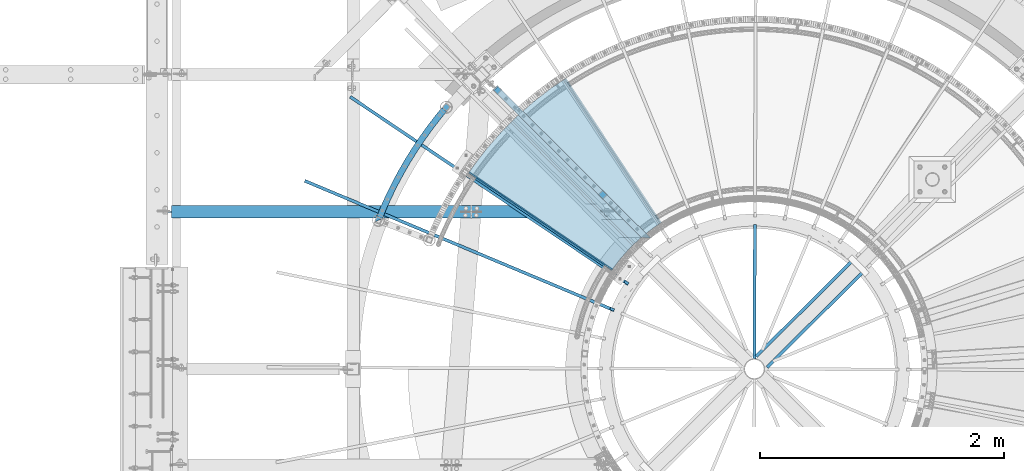
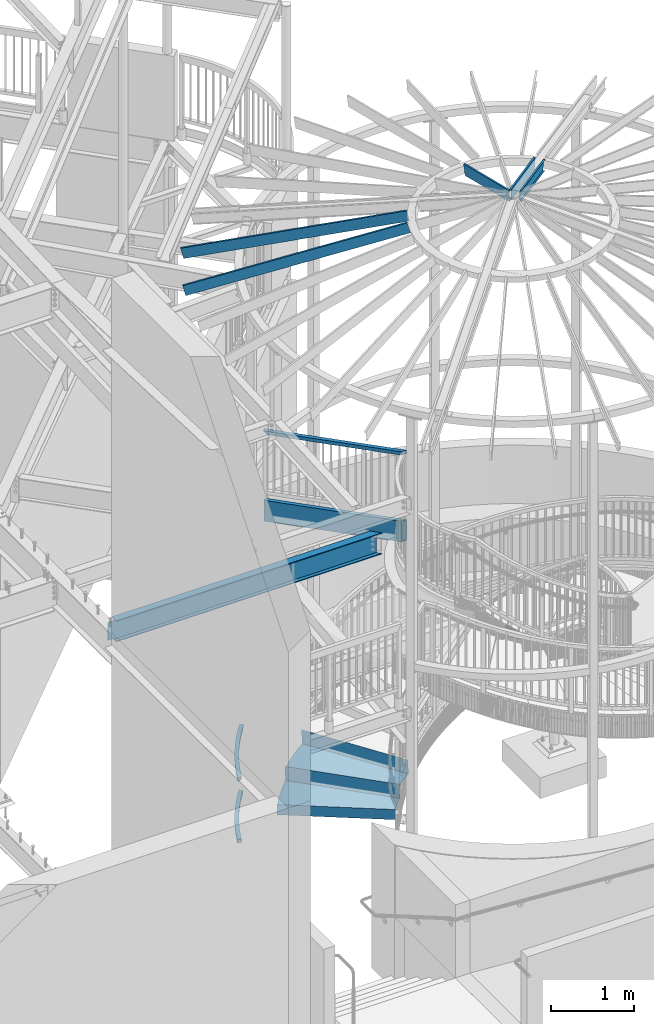
# One storey, part 351 of 975: 13 beams.
"""IFC2X3 building model written with IfcOpenShell, lengths in millimetres."""

from ifc_helpers import new_model, si_unit, frame, origin_with_axes, place, context, subcontext, project, spatial, faceted_brep, material, type_object, element, save


model = new_model("IFC2X3")

# Units and contexts
model_context = context("Model", 3, precision=1e-05, world=origin_with_axes())
body_context = subcontext(model_context, "Body", "Model", "MODEL_VIEW")
ifc_project = project(units=[si_unit("LENGTHUNIT", "METRE", prefix="MILLI"), si_unit("AREAUNIT", "SQUARE_METRE"), si_unit("VOLUMEUNIT", "CUBIC_METRE"), si_unit("MASSUNIT", "GRAM", prefix="KILO"), si_unit("TIMEUNIT", "SECOND"), si_unit("PLANEANGLEUNIT", "RADIAN"), si_unit("SOLIDANGLEUNIT", "STERADIAN"), si_unit("THERMODYNAMICTEMPERATUREUNIT", "DEGREE_CELSIUS"), si_unit("LUMINOUSINTENSITYUNIT", "LUMEN")], contexts=[model_context])

# Site, building, storey
site_placement = place(None, origin_with_axes())
site = spatial("IfcSite", under=ifc_project, at=site_placement, CompositionType="ELEMENT")
building_placement = place(site_placement, origin_with_axes())
building = spatial("IfcBuilding", under=site, at=building_placement, Name="Undefined", CompositionType="ELEMENT")
storey_placement = place(building_placement, origin_with_axes())
storey = spatial("IfcBuildingStorey", under=building, at=storey_placement, Name="Undefined", CompositionType="ELEMENT", Elevation=0.0)

# Beams
ifc_material_1 = material()
beam_type_1 = type_object("IfcBeamType", Name="HSS2X2X.188_TUBES", PredefinedType="NOTDEFINED")
beam_1_placement = place(storey_placement, frame((32625.1078120215, 5693.2540656037, 5130.8), z_axis=(0.0, 0.0, 1.0), x_axis=(0.708992011834515, -0.705216510835394, 0.0)))
element("IfcBeam", 1, at=beam_1_placement, inside=storey, type_object=beam_type_1, material=ifc_material_1, Name="HANDRAIL", ObjectType="HSS2X2X.188_TUBES", context=body_context, shape_type="Brep", body=[
    faceted_brep([(20.6375002484237, 20.6374999999971, -20.6374999999998), (20.6375002484456, -20.637500000008, -20.6374999999998), (1697.54179663167, -20.6375000002336, -20.6374999999998), (1742.99162996408, 20.6374999997752, -20.6374999999998), (-20.6375002658569, -20.6374999999971, 20.6374999999998), (1697.54179663167, -20.6375000002336, 20.6374999999998), (-20.6375002658751, 20.637500000008, 20.6374999999998), (1742.99162996408, 20.6374999997752, 20.6374999999998), (25.4000003077635, 25.3999999999942, -25.3999999999996), (-25.4000003252186, 25.4000000000087, 25.3999999999996), (1748.23584150244, 25.3999999997759, 25.3999999999996), (1748.23584150244, 25.3999999997759, -25.3999999999996), (-25.4000003251967, -25.3999999999942, 25.3999999999996), (1692.29758509331, -25.4000000002306, 25.3999999999996), (25.4000003077854, -25.4000000000087, -25.3999999999996), (1692.29758509331, -25.4000000002306, -25.3999999999996)], [[[0, 1, 2, 3]], [[1, 4, 5, 2]], [[4, 6, 7, 5]], [[6, 0, 3, 7]], [[8, 9, 10, 11]], [[9, 12, 13, 10]], [[12, 14, 15, 13]], [[14, 8, 11, 15]], [[13, 15, 11, 10], [5, 7, 3, 2]], [[14, 12, 9, 8], [6, 4, 1, 0]]]),
])
beam_2_placement = place(storey_placement, frame((31648.9149123785, 4623.21435817746, 1041.4), z_axis=(-0.857559451307456, 0.51438486318442, 0.0), x_axis=(0.514384863184421, 0.857559451307456, 0.0)))
element("IfcBeam", 2, at=beam_2_placement, inside=storey, type_object=beam_type_1, material=ifc_material_1, Name="HANDRAIL", ObjectType="HSS2X2X.188_TUBES", context=body_context, shape_type="Brep", body=[
    faceted_brep([(864.497670977176, -25.4000000000001, 3.14845098929436), (864.497670977176, 25.4, 3.14845098929436), (971.694523908329, 25.4, -9.20257225558089), (971.694523908329, -25.4000000000001, -9.20257225558089), (756.953656478439, -25.4000000000001, 11.9800985725997), (756.953656478439, 25.4, 11.9800985725997), (649.177993567504, -25.4000000000001, 17.2828844110372), (649.177993567504, 25.4, 17.2828844110372), (541.286444213583, -25.4000000000001, 19.0511127759528), (541.286444213583, 25.4, 19.0511127759528), (433.394894859659, -25.4000000000001, 17.2828844111391), (433.394894859659, 25.4, 17.2828844111391), (325.619231948716, -25.4000000000001, 11.9800985728107), (325.619231948716, 25.4, 11.9800985728107), (218.075217449972, -25.4000000000001, 3.14845098960723), (218.075217449972, 25.4, 3.14845098960723), (110.878364518805, -25.4000000000001, -9.2025722551698), (110.878364518805, 25.4, -9.2025722551698), (29.4665174151087, -25.4000000000001, -21.297610330148), (29.4665174151087, 25.4, -21.297610330148), (-4.14381342392153, -25.4000000000001, 25.0597049125827), (-4.14381342392153, 25.4, 25.0597049125827), (-29.1325189401614, 25.4, 20.5057519511611), (-29.1325189401614, -25.4000000000001, 20.5057519511611), (104.237555630552, -25.4000000000001, 41.1614988402289), (104.237555630552, 25.4, 41.1614988402289), (213.088359422138, -25.4000000000001, 53.7030872458672), (213.088359422138, 25.4, 53.7030872458672), (322.291681171508, -25.4000000000001, 62.6709991942953), (322.291681171508, 25.4, 62.6709991942953), (431.730225459367, -25.4000000000001, 68.0556022405071), (431.730225459367, 25.4, 68.0556022405071), (541.286444213616, -25.4000000000001, 69.8511127758793), (541.286444213616, 25.4, 69.8511127758793), (650.842662967862, -25.4000000000001, 68.055602240398), (650.842662967862, 25.4, 68.055602240398), (760.281207255714, -25.4000000000001, 62.6709991940879), (760.281207255714, 25.4, 62.6709991940879), (869.484529005073, -25.4000000000001, 53.7030872455507), (869.484529005073, 25.4, 53.7030872455507), (978.335332796643, -25.4000000000001, 41.1614988398105), (978.335332796643, 25.4, 41.1614988398105), (1086.7167018511, -25.4000000000001, 25.0597049120588), (1111.73237532845, -25.4000000000001, 20.5393322022319), (1086.7167018511, 0.0179933247547979, 25.0597049120588), (1061.60688227827, 25.4, 28.7901720933805), (1053.31897375033, 25.4, -21.3291958836853), (1078.42907500318, -25.4000000000001, -25.0597049130993), (1078.42907500318, 0.0177085913537667, -25.0597049130993), (1103.44446825394, -25.4000000000001, -29.5800269855245), (864.965188917289, 20.6375, 7.88794813831919), (864.965188917289, -20.6375, 7.88794813831919), (972.317099741609, -20.6375, -4.48094059038704), (972.317099741609, 20.6375, -4.48094059038704), (757.265614363809, 20.6375, 16.7323705058661), (757.265614363809, -20.6375, 16.7323705058661), (649.334056323787, 20.6375, 22.0428267075404), (649.334056323787, -20.6375, 22.0428267075404), (541.286444213587, 20.6375, 23.8136127759499), (541.286444213587, -20.6375, 23.8136127759499), (433.238832103383, 20.6375, 22.0428267076459), (433.238832103383, -20.6375, 22.0428267076459), (325.307274063354, 20.6375, 16.7323705060735), (325.307274063354, -20.6375, 16.7323705060735), (217.607699509863, 20.6375, 7.88794813863205), (217.607699509863, -20.6375, 7.88794813863205), (110.255788685528, 20.6375, -4.48094058997231), (110.255788685528, -20.6375, -4.48094058997231), (23.8813338109103, 20.6375, -17.3132537923011), (23.8813338109103, -20.6375, -17.3132537923011), (-23.7281193348681, 20.6375, 16.650363046072), (-23.7281193348681, -20.6375, 16.650363046072), (-3.36684840693488, 20.6375, 20.361010241475), (-3.36684840693488, -20.6375, 20.361010241475), (104.860131463825, 20.6375, 36.439867175035), (104.860131463825, -20.6375, 36.439867175035), (213.555877362247, 20.6375, 48.9635900968387), (213.555877362247, -20.6375, 48.9635900968387), (322.603639056873, 20.6375, 57.9187272610288), (322.603639056873, -20.6375, 57.9187272610288), (431.886288215646, 20.6375, 63.2956599440004), (431.886288215646, -20.6375, 63.2956599440004), (541.286444213612, 20.6375, 65.0886127758895), (541.286444213612, -20.6375, 65.0886127758895), (650.686600211578, 20.6375, 63.2956599438949), (650.686600211578, -20.6375, 63.2956599438949), (759.969249370344, 20.6375, 57.9187272608178), (759.969249370344, -20.6375, 57.9187272608178), (869.017011064956, 20.6375, 48.9635900965259), (869.017011064956, -20.6375, 48.9635900965259), (977.712756963363, 20.6375, 36.4398671746167), (977.712756963363, -20.6375, 36.4398671746167), (1079.20604002018, -20.6375, -20.3610102419916), (1085.93973683411, -20.6375, 20.3610102409548), (1106.26826561141, -20.6375, 16.6876121691785), (1099.53434111337, -20.6375, -24.0343671708761), (1079.20604002018, 0.0177352851101205, -20.3610102419916), (1058.80739391431, 20.6375, -17.3304635819222), (1065.54131959326, 20.6375, 23.3915228994447), (1085.93973683411, 0.0179666309986715, 20.3610102409548)], [[[0, 1, 2, 3]], [[4, 5, 1, 0]], [[6, 7, 5, 4]], [[8, 9, 7, 6]], [[10, 11, 9, 8]], [[12, 13, 11, 10]], [[14, 15, 13, 12]], [[16, 17, 15, 14]], [[17, 16, 18, 19]], [[20, 21, 22, 23]], [[21, 20, 24, 25]], [[25, 24, 26, 27]], [[27, 26, 28, 29]], [[29, 28, 30, 31]], [[31, 30, 32, 33]], [[33, 32, 34, 35]], [[35, 34, 36, 37]], [[37, 36, 38, 39]], [[39, 38, 40, 41]], [[42, 43, 44]], [[41, 40, 42, 44, 45]], [[2, 1, 5, 7, 9, 11, 13, 15, 17, 19, 22, 21, 25, 27, 29, 31, 33, 35, 37, 39, 41, 45, 46]], [[47, 3, 2, 46, 48]], [[47, 48, 49]], [[42, 40, 38, 36, 34, 32, 30, 28, 26, 24, 20, 23, 18, 16, 14, 12, 10, 8, 6, 4, 0, 3, 47, 49, 43]], [[50, 51, 52, 53]], [[54, 55, 51, 50]], [[56, 57, 55, 54]], [[58, 59, 57, 56]], [[60, 61, 59, 58]], [[62, 63, 61, 60]], [[64, 65, 63, 62]], [[66, 67, 65, 64]], [[67, 66, 68, 69]], [[22, 19, 18, 23], [70, 71, 69, 68]], [[72, 73, 71, 70]], [[73, 72, 74, 75]], [[75, 74, 76, 77]], [[77, 76, 78, 79]], [[79, 78, 80, 81]], [[81, 80, 82, 83]], [[83, 82, 84, 85]], [[85, 84, 86, 87]], [[87, 86, 88, 89]], [[89, 88, 90, 91]], [[92, 52, 51, 55, 57, 59, 61, 63, 65, 67, 69, 71, 73, 75, 77, 79, 81, 83, 85, 87, 89, 91, 93, 94, 95]], [[92, 95, 96]], [[53, 52, 92, 96, 97]], [[90, 88, 86, 84, 82, 80, 78, 76, 74, 72, 70, 68, 66, 64, 62, 60, 58, 56, 54, 50, 53, 97, 98]], [[93, 91, 90, 98, 99]], [[93, 99, 94]], [[48, 46, 45, 44, 43, 49], [98, 97, 96, 95, 94, 99]]]),
])
beam_3_placement = place(storey_placement, frame((31648.9149123785, 4623.21435817746, 114.3), z_axis=(-0.857559451307456, 0.51438486318442, 0.0), x_axis=(0.514384863184421, 0.857559451307456, 0.0)))
element("IfcBeam", 3, at=beam_3_placement, inside=storey, type_object=beam_type_1, material=ifc_material_1, Name="HANDRAIL", ObjectType="HSS2X2X.188_TUBES", context=body_context, shape_type="Brep", body=[
    faceted_brep([(864.497670977176, -25.4000000000001, 3.14845098929436), (864.497670977176, 25.4, 3.14845098929436), (971.694523908329, 25.4, -9.20257225558089), (971.694523908329, -25.4000000000001, -9.20257225558089), (756.953656478439, -25.4000000000001, 11.9800985725997), (756.953656478439, 25.4, 11.9800985725997), (649.177993567504, -25.4000000000001, 17.2828844110372), (649.177993567504, 25.4, 17.2828844110372), (541.286444213583, -25.4000000000001, 19.0511127759528), (541.286444213583, 25.4, 19.0511127759528), (433.394894859659, -25.4000000000001, 17.2828844111391), (433.394894859659, 25.4, 17.2828844111391), (325.619231948716, -25.4000000000001, 11.9800985728107), (325.619231948716, 25.4, 11.9800985728107), (218.075217449972, -25.4000000000001, 3.14845098960723), (218.075217449972, 25.4, 3.14845098960723), (110.878364518805, -25.4000000000001, -9.2025722551698), (110.878364518805, 25.4, -9.2025722551698), (29.2714380277321, -25.4, -21.3265925078304), (29.2714380277321, 25.4, -21.3265925078304), (104.237555630552, -25.4000000000001, 41.1614988402289), (104.237555630552, 25.4, 41.1614988402289), (20.9837974593029, 25.4, 28.7928152789318), (20.9837974593029, -25.4, 28.7928152789318), (213.088359422138, -25.4000000000001, 53.7030872458672), (213.088359422138, 25.4, 53.7030872458672), (322.291681171508, -25.4000000000001, 62.6709991942953), (322.291681171508, 25.4, 62.6709991942953), (431.730225459367, -25.4000000000001, 68.0556022405071), (431.730225459367, 25.4, 68.0556022405071), (541.286444213616, -25.4000000000001, 69.8511127758793), (541.286444213616, 25.4, 69.8511127758793), (650.842662967862, -25.4000000000001, 68.055602240398), (650.842662967862, 25.4, 68.055602240398), (760.281207255714, -25.4000000000001, 62.6709991940879), (760.281207255714, 25.4, 62.6709991940879), (869.484529005073, -25.4000000000001, 53.7030872455507), (869.484529005073, 25.4, 53.7030872455507), (978.335332796643, -25.4000000000001, 41.1614988398105), (978.335332796643, 25.4, 41.1614988398105), (1061.60688227917, -25.4, 28.7901720932532), (1061.60688227827, 25.4, 28.7901720933805), (1053.31897375033, 25.4, -21.3291958836853), (1053.31897375123, -25.4, -21.3291958838126), (864.965188917289, 20.6375, 7.88794813831919), (864.965188917289, -20.6375, 7.88794813831919), (972.317099741609, -20.6375, -4.48094059038704), (972.317099741609, 20.6375, -4.48094059038704), (757.265614363809, 20.6375, 16.7323705058661), (757.265614363809, -20.6375, 16.7323705058661), (649.334056323787, 20.6375, 22.0428267075404), (649.334056323787, -20.6375, 22.0428267075404), (541.286444213587, 20.6375, 23.8136127759499), (541.286444213587, -20.6375, 23.8136127759499), (433.238832103383, 20.6375, 22.0428267076459), (433.238832103383, -20.6375, 22.0428267076459), (325.307274063354, 20.6375, 16.7323705060735), (325.307274063354, -20.6375, 16.7323705060735), (217.607699509863, 20.6375, 7.88794813863205), (217.607699509863, -20.6375, 7.88794813863205), (110.255788685528, 20.6375, -4.48094058997231), (110.255788685528, -20.6375, -4.48094058997231), (28.4944717244434, 20.6375, -16.6278980278184), (28.4944717244434, -20.6375, -16.6278980278184), (21.7607637625952, 20.6375, 24.0941207989235), (21.7607637625952, -20.6375, 24.0941207989235), (104.860131463825, 20.6375, 36.439867175035), (104.860131463825, -20.6375, 36.439867175035), (213.555877362247, 20.6375, 48.9635900968387), (213.555877362247, -20.6375, 48.9635900968387), (322.603639056873, 20.6375, 57.9187272610288), (322.603639056873, -20.6375, 57.9187272610288), (431.886288215646, 20.6375, 63.2956599440004), (431.886288215646, -20.6375, 63.2956599440004), (541.286444213612, 20.6375, 65.0886127758895), (541.286444213612, -20.6375, 65.0886127758895), (650.686600211578, 20.6375, 63.2956599438949), (650.686600211578, -20.6375, 63.2956599438949), (759.969249370344, 20.6375, 57.9187272608178), (759.969249370344, -20.6375, 57.9187272608178), (869.017011064956, 20.6375, 48.9635900965259), (869.017011064956, -20.6375, 48.9635900965259), (977.712756963363, 20.6375, 36.4398671746167), (977.712756963363, -20.6375, 36.4398671746167), (1060.82989085467, -20.6375, 24.0914813454001), (1054.09596517572, -20.6375, -16.6305051359632), (1054.09596517572, 20.6375, -16.6305051359632), (1060.82989085467, 20.6375, 24.0914813454001)], [[[0, 1, 2, 3]], [[4, 5, 1, 0]], [[6, 7, 5, 4]], [[8, 9, 7, 6]], [[10, 11, 9, 8]], [[12, 13, 11, 10]], [[14, 15, 13, 12]], [[16, 17, 15, 14]], [[17, 16, 18, 19]], [[20, 21, 22, 23]], [[21, 20, 24, 25]], [[25, 24, 26, 27]], [[27, 26, 28, 29]], [[29, 28, 30, 31]], [[31, 30, 32, 33]], [[33, 32, 34, 35]], [[35, 34, 36, 37]], [[37, 36, 38, 39]], [[39, 38, 40, 41]], [[2, 1, 5, 7, 9, 11, 13, 15, 17, 19, 22, 21, 25, 27, 29, 31, 33, 35, 37, 39, 41, 42]], [[3, 2, 42, 43]], [[38, 36, 34, 32, 30, 28, 26, 24, 20, 23, 18, 16, 14, 12, 10, 8, 6, 4, 0, 3, 43, 40]], [[44, 45, 46, 47]], [[48, 49, 45, 44]], [[50, 51, 49, 48]], [[52, 53, 51, 50]], [[54, 55, 53, 52]], [[56, 57, 55, 54]], [[58, 59, 57, 56]], [[60, 61, 59, 58]], [[61, 60, 62, 63]], [[22, 19, 18, 23], [64, 65, 63, 62]], [[66, 67, 65, 64]], [[67, 66, 68, 69]], [[69, 68, 70, 71]], [[71, 70, 72, 73]], [[73, 72, 74, 75]], [[75, 74, 76, 77]], [[77, 76, 78, 79]], [[79, 78, 80, 81]], [[81, 80, 82, 83]], [[46, 45, 49, 51, 53, 55, 57, 59, 61, 63, 65, 67, 69, 71, 73, 75, 77, 79, 81, 83, 84, 85]], [[47, 46, 85, 86]], [[82, 80, 78, 76, 74, 72, 70, 68, 66, 64, 62, 60, 58, 56, 54, 52, 50, 48, 44, 47, 86, 87]], [[83, 82, 87, 84]], [[42, 41, 40, 43], [86, 85, 84, 87]]]),
])
beam_type_2 = type_object("IfcBeamType", Name="HSS12X2X5/16", PredefinedType="NOTDEFINED")
beam_4_placement = place(storey_placement, frame((32497.9095255267, 5819.77499995673, 3987.8), z_axis=(0.0, 0.0, 1.0), x_axis=(0.708992011834515, -0.705216510835394, 0.0)))
element("IfcBeam", 4, at=beam_4_placement, inside=storey, type_object=beam_type_2, material=ifc_material_1, Name="BEAM", ObjectType="HSS12X2X5/16", context=body_context, shape_type="Brep", body=[
    faceted_brep([(163.532220915233, 17.4624999999905, -144.4625), (163.532220915215, -17.4625000000233, -144.4625), (1881.10440063851, -17.4625000002525, -144.4625), (1919.35985409676, 17.4624999997541, -144.4625), (163.532220915215, -17.4625000000233, 144.4625), (1881.10440063851, -17.4625000002525, 144.4625), (163.532220915233, 17.4624999999905, 144.4625), (1919.35985409676, 17.4624999997541, 144.4625), (163.53222091524, 25.3999999999905, -152.4), (163.53222091524, 25.3999999999905, 152.4), (1928.05427533727, 25.3999999997541, 152.4), (1928.05427533727, 25.3999999997541, -152.4), (163.532220915207, -25.4000000000269, 152.4), (1872.409979398, -25.4000000002525, 152.4), (163.532220915207, -25.4000000000269, -152.4), (1872.409979398, -25.4000000002525, -152.4)], [[[0, 1, 2, 3]], [[1, 4, 5, 2]], [[4, 6, 7, 5]], [[6, 0, 3, 7]], [[8, 9, 10, 11]], [[9, 12, 13, 10]], [[12, 14, 15, 13]], [[14, 8, 11, 15]], [[13, 15, 11, 10], [5, 7, 3, 2]], [[14, 12, 9, 8], [6, 4, 1, 0]]]),
])
ifc_material_2 = material(Name="STEEL/A36")
beam_type_3 = type_object("IfcBeamType", PredefinedType="NOTDEFINED")
beam_5_placement = place(storey_placement, frame((33207.148607825, 4973.34572021449, 336.516955742185), z_axis=(-0.702851761482393, 0.711336348980633, 3.56753389496589e-10), x_axis=(-0.50299075601211, -0.496991247011839, 0.70710678101683)))
element("IfcBeam", 5, at=beam_5_placement, inside=storey, type_object=beam_type_3, material=ifc_material_2, Name="TREAD", context=body_context, shape_type="Brep", body=[
    faceted_brep([(25.4000001621371, 1.5874997143419, 653.28751700326), (1.61144271260127e-08, 1.58750000026703, 653.458911680114), (-1.96268956642598e-08, -1.58749999973588, 653.437487347819), (15.8745748038546, -1.5875001784334, 653.330368544412), (-120.373022221533, -103.76749224318, 653.560250726816), (-154.208562872085, -137.603032237963, 653.560249286144), (-49.0005534961238, -242.811041643061, 652.140399877677), (-46.7554894721361, -240.565977619684, 652.140399877557), (-149.718432901582, -137.603030988068, 653.529952160912), (-118.287540217565, -106.172138299769, 653.529952144057), (82.2634121742994, -374.075007349978, 638.193006315465), (84.508476198167, -371.829943326711, 638.193006315345), (212.601306559884, -504.412901568812, 612.134347567509), (214.846370562875, -502.167837565145, 612.134347570151), (261.055176792581, -530.596712595621, 601.111823144849), (259.197053542079, -528.103470062568, 601.754434690294), (248.701623596196, -536.023091227627, 602.134831213494), (248.362633442506, -540.174228440612, 601.571851715846), (250.921725105154, -538.24319290819, 601.479100122608), (25.4000001865188, 1.58749971376164, -768.618736200977), (-118.287540216395, -106.172138302336, -768.542582766611), (-149.718433278054, -137.603031368186, -768.542582749815), (-92.8426928760819, -194.478774201189, -768.783692225286), (-95.087756899542, -196.723838224048, -768.783692225159), (-154.208562871598, -137.603032235413, -768.533065523057), (-120.373022220361, -103.767492245748, -768.533065418116), (15.8745748282345, -1.58750017901184, -768.605275732323), (-1.58015609486029e-08, -1.58750000031432, -768.571627720263), (1.99397618416697e-08, 1.58749999968677, -768.564897939472), (-21.2434099455131, -266.078057151808, -776.330856581004), (-23.4884739689005, -268.323121174595, -776.330856580884), (49.7927349215133, -337.114201961485, -791.08236047571), (47.5476709198538, -339.35926596382, -791.082360478347), (66.437802308692, -335.979336534963, -793.502619428495), (56.3071310127107, -343.628597994977, -793.115412720523), (53.7487404151489, -345.560335457225, -793.01762786691), (54.0919957188744, -341.413461775162, -792.424099714608), (64.5845451579717, -333.490960101732, -792.825137753654)], [[[0, 1, 2, 3, 4, 5, 6, 7, 8, 9]], [[7, 6, 10, 11]], [[11, 10, 12, 13]], [[14, 15, 16, 13, 12, 17, 18]], [[19, 20, 21, 22, 23, 24, 25, 26, 27, 28]], [[29, 30, 23, 22]], [[31, 32, 30, 29]], [[33, 34, 35, 32, 31, 36, 37]], [[34, 33, 14, 18]], [[35, 34, 18, 17]], [[10, 6, 5, 24, 23, 30, 32, 35, 17, 12]], [[25, 24, 5, 4]], [[26, 25, 4, 3]], [[27, 26, 3, 2]], [[28, 27, 2, 1]], [[19, 28, 1, 0]], [[20, 19, 0, 9]], [[20, 9, 8, 21]], [[36, 31, 29, 22, 21, 8, 7, 11, 13, 16]], [[37, 36, 16, 15]], [[33, 37, 15, 14]]]),
])
beam_6_placement = place(storey_placement, frame((33539.9816387681, 5239.36408778833, 514.316955742184), z_axis=(-0.551824206033802, 0.833960458076499, -1.40206566356938e-11), x_axis=(-0.589699095154169, -0.390198638102022, 0.707106781184909)))
element("IfcBeam", 6, at=beam_6_placement, inside=storey, type_object=beam_type_3, material=ifc_material_2, Name="TREAD", context=body_context, shape_type="Brep", body=[
    faceted_brep([(25.4000001621371, 1.5874997143419, 653.28751700326), (1.61144271260127e-08, 1.58750000026703, 653.458911680114), (-1.96268956642598e-08, -1.58749999973588, 653.437487347819), (15.8745748038546, -1.5875001784334, 653.330368544412), (-120.373022221533, -103.76749224318, 653.560250726816), (-154.208562872085, -137.603032237963, 653.560249286144), (-49.0005534961238, -242.811041643061, 652.140399877677), (-46.7554894721361, -240.565977619684, 652.140399877557), (-149.718432901582, -137.603030988068, 653.529952160912), (-118.287540217565, -106.172138299769, 653.529952144057), (82.2634121742994, -374.075007349978, 638.193006315465), (84.508476198167, -371.829943326711, 638.193006315345), (212.601306559884, -504.412901568812, 612.134347567509), (214.846370562875, -502.167837565145, 612.134347570151), (261.055176792581, -530.596712595621, 601.111823144849), (259.197053542079, -528.103470062568, 601.754434690294), (248.701623596196, -536.023091227627, 602.134831213494), (248.362633442506, -540.174228440612, 601.571851715846), (250.921725105154, -538.24319290819, 601.479100122608), (25.4000001865188, 1.58749971376164, -768.618736200977), (-118.287540216395, -106.172138302336, -768.542582766611), (-149.718433278054, -137.603031368186, -768.542582749815), (-92.8426928760819, -194.478774201189, -768.783692225286), (-95.087756899542, -196.723838224048, -768.783692225159), (-154.208562871598, -137.603032235413, -768.533065523057), (-120.373022220361, -103.767492245748, -768.533065418116), (15.8745748282345, -1.58750017901184, -768.605275732323), (-1.58015609486029e-08, -1.58750000031432, -768.571627720263), (1.99397618416697e-08, 1.58749999968677, -768.564897939472), (-21.2434099455131, -266.078057151808, -776.330856581004), (-23.4884739689005, -268.323121174595, -776.330856580884), (49.7927349215133, -337.114201961485, -791.08236047571), (47.5476709198538, -339.35926596382, -791.082360478347), (66.437802308692, -335.979336534963, -793.502619428495), (56.3071310127107, -343.628597994977, -793.115412720523), (53.7487404151489, -345.560335457225, -793.01762786691), (54.0919957188744, -341.413461775162, -792.424099714608), (64.5845451579717, -333.490960101732, -792.825137753654)], [[[0, 1, 2, 3, 4, 5, 6, 7, 8, 9]], [[7, 6, 10, 11]], [[11, 10, 12, 13]], [[14, 15, 16, 13, 12, 17, 18]], [[19, 20, 21, 22, 23, 24, 25, 26, 27, 28]], [[29, 30, 23, 22]], [[31, 32, 30, 29]], [[33, 34, 35, 32, 31, 36, 37]], [[34, 33, 14, 18]], [[35, 34, 18, 17]], [[10, 6, 5, 24, 23, 30, 32, 35, 17, 12]], [[25, 24, 5, 4]], [[26, 25, 4, 3]], [[27, 26, 3, 2]], [[28, 27, 2, 1]], [[19, 28, 1, 0]], [[20, 19, 0, 9]], [[20, 9, 8, 21]], [[36, 31, 29, 22, 21, 8, 7, 11, 13, 16]], [[37, 36, 16, 15]], [[33, 37, 15, 14]]]),
])
beam_type_4 = type_object("IfcBeamType", PredefinedType="NOTDEFINED")
beam_7_placement = place(storey_placement, frame((32932.1197089709, 4647.9187645533, 158.716955742187), z_axis=(-0.827279192601265, 0.561791008729224, 0.0), x_axis=(-0.397246232039211, -0.584974727057566, 0.707106781069575)))
element("IfcBeam", 7, at=beam_7_placement, inside=storey, type_object=beam_type_4, material=ifc_material_2, Name="TREAD", context=body_context, shape_type="Brep", body=[
    faceted_brep([(-108.024103315862, -98.4749899792641, 653.512634185849), (-110.291967367199, -96.2071228216955, 653.543240485535), (-110.291967490137, -96.2071229221528, -768.538408417367), (-108.02410343884, -98.4749900796833, -768.548022419873), (-1.58015609486029e-08, -1.58750000031432, -768.571627720263), (15.8745748282345, -1.58750017901184, -768.605275732323), (15.8745748038546, -1.5875001784334, 653.330368544412), (-1.96268956642598e-08, -1.58749999973588, 653.437487347819), (1.99397618416697e-08, 1.58749999968677, -768.564897939472), (1.61144271260127e-08, 1.58750000026703, 653.458911680114), (25.4000001865188, 1.58749971376164, -768.618736200977), (25.4000001621371, 1.5874997143419, 653.28751700326)], [[[0, 1, 2, 3]], [[4, 5, 6, 7]], [[8, 4, 7, 9]], [[10, 8, 9, 11]], [[10, 11, 0, 3]], [[5, 4, 8, 10, 3, 2]], [[6, 5, 2, 1]], [[11, 9, 7, 6, 1, 0]]]),
])
ifc_material_3 = material(Name="STEEL/Zero_Density")
beam_type_5 = type_object("IfcBeamType", PredefinedType="NOTDEFINED")
for number, where, z_axis, x_axis, name in (
    (8, (33684.567579328, 4110.30252055122, 8885.0313138005), (-0.201171189303168, 0.13548706120418, 0.970140922155438), (-0.804662506696911, 0.541933260795873, -0.242541936908643), "STUD"),
    (9, (33566.8709140829, 3891.89177573643, 8885.0313138005), (-0.223737955733079, 0.0936371633068038, 0.970140922140819), (-0.894927076878677, 0.374538296949224, -0.242541936967119), "STUD"),
):
    element("IfcBeam", number, at=place(storey_placement, frame(where, z_axis=z_axis, x_axis=x_axis)), inside=storey, type_object=beam_type_5, material=ifc_material_3, Name=name, context=body_context, shape_type="Brep", body=[
        faceted_brep([(-1.67347025126219e-10, 12.6999999998588, -76.2000000000985), (1.96450855582952e-10, 12.7000000001644, 76.2000000001021), (2798.98467503002, 12.7000000041553, 76.2000000028588), (2798.98467502966, 12.7000000038533, -76.1999999973427), (1.74622982740402e-10, -12.6999999998661, 76.2000000000985), (2798.98467503, -12.6999999958753, 76.2000000028534), (1.67347025126219e-10, -12.6999999998698, 73.0250000000947), (2798.98467502999, -12.6999999958789, 73.0250000028504), (1.89174897968769e-10, 9.52500000015425, 73.0250000000974), (2798.98467503001, 9.52500000414511, 73.0250000028532), (-1.60071067512035e-10, 9.52499999986321, -73.0250000000938), (2798.98467502966, 9.52500000385407, -73.0249999973398), (-1.81898940354586e-10, -12.7000000001608, -73.0250000000965), (2798.98467502964, -12.6999999961699, -73.0249999973416), (-1.92812876775861e-10, -12.7000000001717, -76.2000000001003), (2798.98467502963, -12.6999999961772, -76.1999999973455)], [[[0, 1, 2, 3]], [[1, 4, 5, 2]], [[4, 6, 7, 5]], [[6, 8, 9, 7]], [[8, 10, 11, 9]], [[10, 12, 13, 11]], [[12, 14, 15, 13]], [[14, 0, 3, 15]], [[5, 7, 9, 11, 13, 15, 3, 2]], [[14, 12, 10, 8, 6, 4, 1, 0]]]),
    ])
for number, where, z_axis, x_axis, name in (
    (10, (34734.3934751894, 3469.13241044937, 9185.06096723024), (0.000888649999629706, 0.242540308898346, 0.970140922165782), (0.00355450199805182, 0.970134410469095, -0.24254193686727), "STUD"),
    (11, (34825.829846795, 3404.88117704727, 9185.06096723024), (0.17213026717781, 0.170873527176511, 0.970140922150774), (0.688502032793625, 0.683475207795133, -0.242541936927299), "STUD"),
):
    element("IfcBeam", number, at=place(storey_placement, frame(where, z_axis=z_axis, x_axis=x_axis)), inside=storey, type_object=beam_type_5, material=ifc_material_3, Name=name, context=body_context, shape_type="Brep", body=[
        faceted_brep([(1134.70057945789, -12.6999999990348, 76.200000000108), (1134.70057945789, -12.6999999990367, 73.0250000001097), (1134.70057945792, 9.52500000095824, 73.025000000097), (1134.70057945806, 9.52500000092914, -73.0249999998405), (1134.70057945804, -12.6999999990658, -73.0249999998296), (1134.70057945805, -12.6999999990658, -76.1999999998279), (1134.70057945806, 12.7000000009302, -76.1999999998443), (1134.70057945791, 12.700000000963, 76.2000000000953), (38.1010538948394, -12.7000000000157, -76.1999999999643), (38.1010539016352, 12.6999999999862, -76.1999999999662), (1.96450855582952e-10, 12.7000000001644, 76.2000000001021), (1.74622982740402e-10, -12.6999999998661, 76.2000000000985), (0.79377234254207, -12.699999999993, 73.0249999999905), (0.793772348486527, 9.52500000000873, 73.0249999999905), (37.3072819528606, 9.52499999998645, -73.0249999999669), (37.3072819469235, -12.7000000000148, -73.0249999999651)], [[[0, 1, 2, 3, 4, 5, 6, 7]], [[6, 5, 8, 9]], [[7, 6, 9, 10]], [[0, 7, 10, 11]], [[1, 0, 11, 12]], [[2, 1, 12, 13]], [[3, 2, 13, 14]], [[4, 3, 14, 15]], [[5, 4, 15, 8]], [[14, 13, 12, 11, 10, 9, 8, 15]]]),
    ])
beam_8_placement = place(storey_placement, frame((35517.6474087407, 4270.50470691658, 8909.8484911832), z_axis=(0.17213026717781, 0.170873527176511, 0.970140922150774), x_axis=(-0.688502112820794, -0.683475127155158, 0.242541936995532)))
element("IfcBeam", 12, at=beam_8_placement, inside=storey, type_object=beam_type_5, material=ifc_material_3, Name="STUD", context=body_context, shape_type="Brep", body=[
    faceted_brep([(-1.92812876775861e-10, -12.7000000001717, -76.2000000001003), (-1.81898940354586e-10, -12.7000000001608, -73.0250000000965), (-1.60071067512035e-10, 9.52499999986321, -73.0250000000938), (1.89174897968769e-10, 9.52500000015425, 73.0250000000974), (1.67347025126219e-10, -12.6999999998698, 73.0250000000947), (1.74622982740402e-10, -12.6999999998661, 76.2000000000985), (1.96450855582952e-10, 12.7000000001644, 76.2000000001021), (-1.67347025126219e-10, 12.6999999998588, -76.2000000000985), (1134.70057945789, -12.6999999990348, 76.200000000108), (1134.70057945791, 12.700000000963, 76.2000000000953), (1096.59952564954, 12.6999999982763, -76.1999999995651), (1096.59952565276, -12.7000000017433, -76.1999999995523), (1097.39329760113, -12.700000001747, -73.0249999995513), (1097.39329759832, 9.52499999827342, -73.0249999995613), (1133.90680722362, 9.5249999982334, 73.0250000005217), (1133.90680722643, -12.7000000017833, 73.0250000005308)], [[[0, 1, 2, 3, 4, 5, 6, 7]], [[8, 9, 6, 5]], [[7, 6, 9, 10]], [[0, 7, 10, 11]], [[1, 0, 11, 12]], [[2, 1, 12, 13]], [[3, 2, 13, 14]], [[4, 3, 14, 15]], [[5, 4, 15, 8]], [[14, 13, 12, 11, 10, 9, 8, 15]]]),
])
ifc_material_4 = material(Name="STEEL/A992")
beam_type_6 = type_object("IfcBeamType", Name="W12X22", PredefinedType="NOTDEFINED")
beam_9_placement = place(storey_placement, frame((29832.3, 4692.649609375, 3781.425), z_axis=(0.0, 0.0, 1.0), x_axis=(1.0, 0.0, 0.0)))
element("IfcBeam", 13, at=beam_9_placement, inside=storey, type_object=beam_type_6, material=ifc_material_4, Name="BEAM", ObjectType="W12X22", context=body_context, shape_type="Brep", body=[
    faceted_brep([(29.3687500000015, -3.17500000000018, -130.174999999999), (29.3687500000015, 3.17500000000018, -130.174999999999), (105.568750190741, 3.17500000000018, -130.174999999999), (105.568750190741, -3.17500000000018, -130.174999999999), (110.428829708788, 3.17500000000018, -131.141729922587), (110.428829708788, -3.17500000000018, -131.141729922587), (114.549006176941, 3.17500000000018, -133.894743823065), (114.549006176941, -3.17500000000018, -133.894743823065), (117.302020077419, 3.17500000000018, -138.014920291218), (117.302020077419, -3.17500000000018, -138.014920291218), (118.268750000007, -3.17500000000018, -142.874999809264), (118.268750000007, 3.17500000000018, -142.874999809264), (118.268750000007, 3.17500000000018, -144.4625), (118.268750000007, 50.8000000000002, -144.4625), (118.268750000007, 50.8000000000002, -155.575), (118.268750000007, -50.8000000000002, -155.575), (118.268750000007, -50.8000000000002, -144.4625), (118.268750000007, -3.17500000000018, -144.4625), (3795.81518607363, -50.8000000000002, 144.4625), (3795.81518607363, -50.8000000000002, 155.575), (118.268750000007, -50.8000000000002, 155.575), (118.268750000007, -50.8000000000002, 144.4625), (3693.67125255022, 50.8000000000002, 155.575), (118.268750000007, 50.8000000000002, 155.575), (3693.67125255022, 50.8000000000002, 144.4625), (118.268750000007, 50.8000000000002, 144.4625), (3741.55122138932, 3.17500000000018, 144.4625), (118.268750000007, 3.17500000000018, 144.4625), (105.568750190741, -3.17500000000018, 130.175000000001), (105.568750190741, 3.17500000000018, 130.175000000001), (29.3687500000015, 3.17500000000018, 130.175000000001), (29.3687500000015, -3.17500000000018, 130.175000000001), (110.428829708788, -3.17500000000018, 131.141729922589), (110.428829708788, 3.17500000000018, 131.141729922589), (114.549006176941, -3.17500000000018, 133.894743823067), (114.549006176941, 3.17500000000018, 133.894743823067), (117.302020077419, -3.17500000000018, 138.014920291221), (117.302020077419, 3.17500000000018, 138.014920291221), (118.268750000007, -3.17500000000018, 142.874999809266), (118.268750000007, 3.17500000000018, 142.874999809266), (118.268750000007, -3.17500000000018, 144.4625), (3747.93521723453, -3.17500000000018, 144.4625), (3741.55122138932, 3.17500000000018, -144.4625), (3747.93521723453, -3.17500000000018, -144.4625), (3795.81518607363, -50.8000000000002, -144.4625), (3795.81518607363, -50.8000000000002, -155.575), (3693.67125255022, 50.8000000000002, -155.575), (3693.67125255022, 50.8000000000002, -144.4625)], [[[0, 1, 2, 3]], [[3, 2, 4, 5]], [[5, 4, 6, 7]], [[7, 6, 8, 9]], [[10, 11, 12, 13, 14, 15, 16, 17]], [[9, 8, 11, 10]], [[18, 19, 20, 21]], [[19, 22, 23, 20]], [[22, 24, 25, 23]], [[24, 26, 27, 25]], [[28, 29, 30, 31]], [[32, 33, 29, 28]], [[34, 35, 33, 32]], [[36, 37, 35, 34]], [[38, 39, 37, 36]], [[20, 23, 25, 27, 39, 38, 40, 21]], [[41, 18, 21, 40]], [[42, 26, 24, 22, 19, 18, 41, 43, 44, 45, 46, 47]], [[44, 43, 17, 16]], [[45, 44, 16, 15]], [[46, 45, 15, 14]], [[47, 46, 14, 13]], [[42, 47, 13, 12]], [[6, 4, 2, 1, 30, 29, 33, 35, 37, 39, 27, 26, 42, 12, 11, 8]], [[31, 30, 1, 0]], [[43, 41, 40, 38, 36, 34, 32, 28, 31, 0, 3, 5, 7, 9, 10, 17]]]),
])

save(model, "model.ifc")
